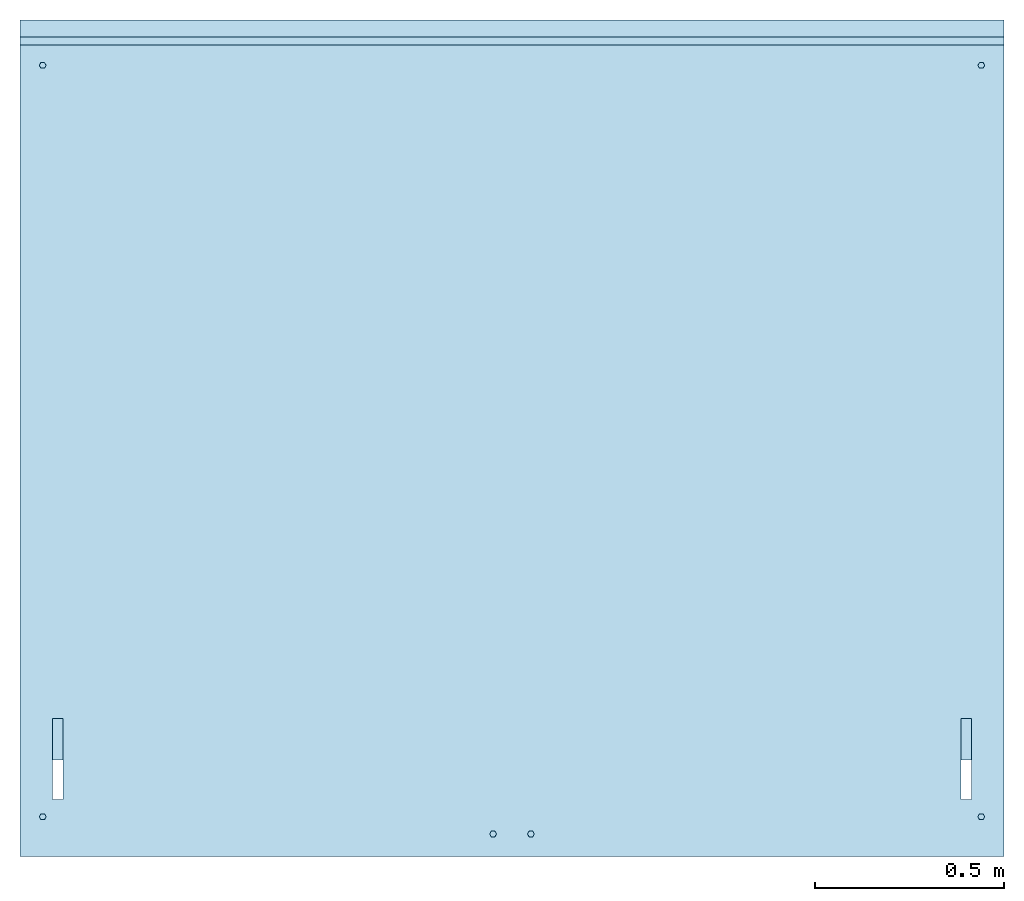
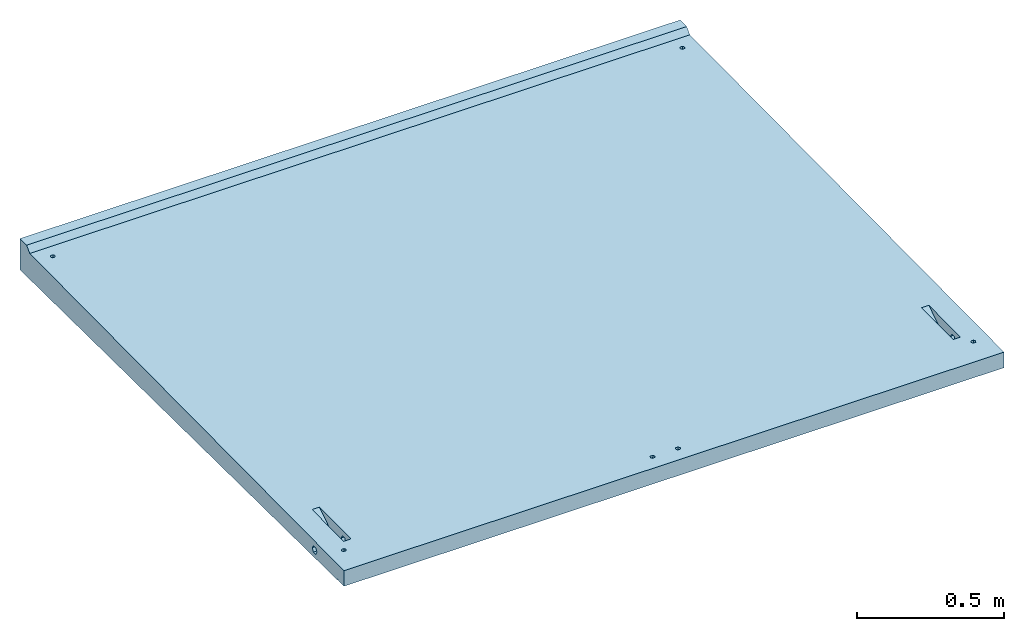
# One storey: 1 slab.
"""IFC2X3 building model written with IfcOpenShell, lengths in millimetres."""

from ifc_helpers import new_model, entity, si_unit, converted_unit, derived_unit, direction, frame, origin, place, context, subcontext, project, spatial, faceted_brep, material, type_object, element, save


model = new_model("IFC2X3")

# Units and contexts
model_context = context("Model", 3, precision=0.01, world=origin(), true_north=direction((6.12303176911189e-17, 1.0)))
body_context = subcontext(model_context, "Body", "Model", "MODEL_VIEW")
ifc_project = project(units=[si_unit("LENGTHUNIT", "METRE", prefix="MILLI"), si_unit("AREAUNIT", "SQUARE_METRE"), si_unit("VOLUMEUNIT", "CUBIC_METRE"), converted_unit("PLANEANGLEUNIT", "DEGREE", entity("IfcRatioMeasure", 0.0174532925199433), si_unit("PLANEANGLEUNIT", "RADIAN"), dimensions=[0, 0, 0, 0, 0, 0, 0]), si_unit("MASSUNIT", "GRAM", prefix="KILO"), derived_unit("MASSDENSITYUNIT", [(si_unit("MASSUNIT", "GRAM", prefix="KILO"), 1), (si_unit("LENGTHUNIT", "METRE"), -3)]), derived_unit("MOMENTOFINERTIAUNIT", [(si_unit("LENGTHUNIT", "METRE"), 4)]), si_unit("TIMEUNIT", "SECOND"), si_unit("FREQUENCYUNIT", "HERTZ"), si_unit("THERMODYNAMICTEMPERATUREUNIT", "DEGREE_CELSIUS"), derived_unit("THERMALTRANSMITTANCEUNIT", [(si_unit("MASSUNIT", "GRAM", prefix="KILO"), 1), (si_unit("THERMODYNAMICTEMPERATUREUNIT", "KELVIN"), -1), (si_unit("TIMEUNIT", "SECOND"), -3)]), derived_unit("VOLUMETRICFLOWRATEUNIT", [(si_unit("LENGTHUNIT", "METRE"), 3), (si_unit("TIMEUNIT", "SECOND"), -1)]), si_unit("ELECTRICCURRENTUNIT", "AMPERE"), si_unit("ELECTRICVOLTAGEUNIT", "VOLT"), si_unit("POWERUNIT", "WATT"), si_unit("FORCEUNIT", "NEWTON", prefix="KILO"), si_unit("ILLUMINANCEUNIT", "LUX"), si_unit("LUMINOUSFLUXUNIT", "LUMEN"), si_unit("LUMINOUSINTENSITYUNIT", "CANDELA"), derived_unit("USERDEFINED", [(si_unit("MASSUNIT", "GRAM", prefix="KILO"), -1), (si_unit("LENGTHUNIT", "METRE"), -2), (si_unit("TIMEUNIT", "SECOND"), 3), (si_unit("LUMINOUSFLUXUNIT", "LUMEN"), 1)]), derived_unit("LINEARVELOCITYUNIT", [(si_unit("LENGTHUNIT", "METRE"), 1), (si_unit("TIMEUNIT", "SECOND"), -1)]), si_unit("PRESSUREUNIT", "PASCAL"), derived_unit("USERDEFINED", [(si_unit("LENGTHUNIT", "METRE"), -2), (si_unit("MASSUNIT", "GRAM", prefix="KILO"), 1), (si_unit("TIMEUNIT", "SECOND"), -2)]), derived_unit("LINEARFORCEUNIT", [(si_unit("MASSUNIT", "GRAM", prefix="KILO"), 1), (si_unit("LENGTHUNIT", "METRE"), 1), (si_unit("TIMEUNIT", "SECOND"), -2), (si_unit("LENGTHUNIT", "METRE"), -1)]), derived_unit("PLANARFORCEUNIT", [(si_unit("MASSUNIT", "GRAM", prefix="KILO"), 1), (si_unit("LENGTHUNIT", "METRE"), 1), (si_unit("TIMEUNIT", "SECOND"), -2), (si_unit("LENGTHUNIT", "METRE"), -2)])], contexts=[model_context])

# Site, building, storey
site_placement = place(None, origin())
site = spatial("IfcSite", under=ifc_project, at=site_placement, CompositionType="ELEMENT")
building_placement = place(site_placement, origin())
building = spatial("IfcBuilding", under=site, at=building_placement, CompositionType="ELEMENT")
storey_placement = place(building_placement, origin())
storey = spatial("IfcBuildingStorey", under=building, at=storey_placement, Name="Begane Grond", CompositionType="ELEMENT", Elevation=0.0)

# Slab
ifc_material = material(Name="beton_prefab-element")
slab_type = type_object("IfcSlabType", PredefinedType="FLOOR", material=ifc_material)
slab_placement = place(storey_placement, frame((-4979.78640975478, -21298.0180129676, -54.5999999999827)))
element("IfcSlab", 1, at=slab_placement, inside=storey, type_object=slab_type, Name="23_GM_Standaard con R21:con, 2000x2600x65/115", PredefinedType="FLOOR", context=body_context, shape_type="Brep", body=[
    faceted_brep([(64.4999999999962, 97.2057713659394, 48.0600005145843), (69.0, 105.0, 48.0600005145843), (64.4999999999962, 112.794228634056, 48.0600005145843), (55.499999999996, 112.794228634056, 48.0600005145843), (51.0, 105.0, 48.0600005145843), (55.499999999996, 97.2057713659394, 48.0600005145843), (1245.5, 67.0942286340536, 48.0600005145843), (1241.0, 59.2999999999952, 48.0600005145843), (1245.5, 51.5057713659368, 48.0600005145843), (1254.5, 51.5057713659368, 48.0600005145843), (1259.0, 59.2999999999952, 48.0600005145843), (1254.5, 67.0942286340536, 48.0600005145843), (2544.5, 97.2057713659307, 48.0600005145843), (2549.0, 105.0, 48.0600005145843), (2544.5, 112.794228634048, 48.0600005145843), (2535.5, 112.794228634048, 48.0600005145843), (2531.0, 105.0, 48.0600005145843), (2535.5, 97.2057713659307, 48.0600005145843), (1345.5, 67.0942286340536, 48.0600005145843), (1341.0, 59.2999999999952, 48.0600005145843), (1345.5, 51.5057713659324, 48.0600005145843), (1354.5, 51.5057713659324, 48.0600005145843), (1359.0, 59.2999999999952, 48.0600005145843), (1354.5, 67.0942286340536, 48.0600005145843), (55.4999999999993, 2082.20577136594, 67.9100005145707), (64.4999999999994, 2082.20577136594, 67.9100005145707), (69.0, 2090.0, 67.9100005145707), (64.4999999999994, 2097.79422863406, 67.9100005145707), (55.4999999999993, 2097.79422863406, 67.9100005145707), (51.0, 2090.0, 67.9100005145707), (2535.5, 2082.20577136594, 67.9100005145707), (2544.5, 2082.20577136594, 67.9100005145707), (2549.0, 2090.0, 67.9100005145707), (2544.5, 2097.79422863406, 67.9100005145707), (2535.5, 2097.79422863406, 67.9100005145707), (2531.0, 2090.0, 67.9100005145707), (2514.67446595528, 192.0, 38.2435935394484), (2514.67446595528, 190.182514765439, 41.3915703077247), (2514.67446595528, 188.36502953087, 44.539547076001), (2514.67446595528, 186.182514765436, 48.3197735380003), (2514.67446595528, 184.0, 52.0999999999995), (2600.0, 184.0, 52.0999999999995), (2600.0, 186.182514767506, 48.3197735344125), (2600.0, 188.0, 45.171796769724), (2600.0, 190.0, 41.7076951545862), (2600.0, 192.0, 38.2435935394484), (114.075534044746, 192.0, 38.2435935394484), (114.075534044746, 190.605222844014, 40.6594184388577), (114.075534044746, 189.210445688023, 43.075243338267), (114.075534044745, 186.60522284401, 47.5876216691333), (114.075534044746, 184.0, 52.0999999999995), (400.0, 184.0, 52.0999999999995), (400.0, 186.605222844123, 47.5876216689416), (400.0, 188.0, 45.171796769724), (400.0, 190.0, 41.7076951545862), (400.0, 192.0, 38.2435935394484), (2200.0, 192.0, 38.2435935394484), (2200.0, 190.605222844014, 40.6594184388616), (2200.0, 189.210445688023, 43.0752433382748), (2200.0, 186.60522284401, 47.5876216691372), (2200.0, 184.0, 52.0999999999995), (2485.92446595528, 184.0, 52.0999999999994), (2485.92446595528, 186.605222844075, 47.5876216690292), (2485.92446595528, 188.0, 45.171796769724), (2485.92446595528, 190.0, 41.7076951545862), (2485.92446595528, 192.0, 38.2435935394484), (0.0, 192.0, 38.2435935394484), (0.0, 190.182514761589, 41.3915703143931), (0.0, 188.365029523169, 44.5395470893379), (0.0, 186.182514761585, 48.3197735446687), (0.0, 184.0, 52.0999999999995), (85.3255340447465, 184.0, 52.0999999999994), (85.3255340447465, 186.182514762092, 48.3197735437932), (85.3255340447465, 188.0, 45.171796769724), (85.3255340447465, 190.0, 41.7076951545862), (85.3255340447465, 192.0, 38.2435935394484), (2600.0, 200.0, 38.2435935394484), (2600.0, 204.0, 38.2435935394484), (2600.0, 208.0, 38.2435935394483), (2514.67446595528, 208.0, 38.2435935394483), (2514.67446595528, 204.0, 38.2435935394484), (2514.67446595528, 200.0, 38.2435935394484), (2514.67446595528, 196.0, 38.2435935394484), (2600.0, 196.0, 38.2435935394484), (400.0, 200.0, 38.2435935394484), (400.0, 204.0, 38.2435935394484), (400.0, 208.0, 38.2435935394483), (114.075534044746, 208.0, 38.2435935394483), (114.075534044746, 204.0, 38.2435935394484), (114.075534044746, 200.0, 38.2435935394484), (114.075534044746, 196.0, 38.2435935394484), (400.0, 196.0, 38.2435935394484), (2485.92446595528, 208.0, 38.2435935394483), (2200.0, 208.0, 38.2435935394483), (2200.0, 204.0, 38.2435935394484), (2200.0, 200.0, 38.2435935394484), (2200.0, 196.0, 38.2435935394484), (2485.92446595528, 196.0, 38.2435935394484), (2485.92446595528, 200.0, 38.2435935394484), (2485.92446595528, 204.0, 38.2435935394484), (85.3255340447465, 208.0, 38.2435935394483), (0.0, 208.0, 38.2435935394483), (0.0, 204.0, 38.2435935394484), (0.0, 200.0, 38.2435935394484), (0.0, 196.0, 38.2435935394484), (85.3255340447465, 196.0, 38.2435935394484), (85.3255340447465, 200.0, 38.2435935394484), (85.3255340447465, 204.0, 38.2435935394484), (2600.0, 210.0, 41.7076951545861), (2600.0, 212.0, 45.1717967697239), (2600.0, 213.817485237319, 48.3197735427603), (2600.0, 216.0, 52.0999999999994), (2514.67446595528, 216.0, 52.0999999999993), (2514.67446595528, 214.0, 48.6358983848615), (2514.67446595528, 212.0, 45.1717967697238), (2514.67446595528, 210.0, 41.7076951545861), (400.0, 210.0, 41.7076951545861), (400.0, 212.0, 45.1717967697238), (400.0, 213.394777155968, 47.5876216690946), (400.0, 216.0, 52.0999999999995), (114.075534044746, 216.0, 52.0999999999995), (114.075534044745, 214.0, 48.6358983848615), (114.075534044746, 212.0, 45.1717967697238), (114.075534044746, 210.0, 41.7076951545861), (2200.0, 214.0, 48.6358983848615), (2200.0, 212.0, 45.1717967697238), (2200.0, 210.0, 41.7076951545861), (2485.92446595528, 210.0, 41.7076951545861), (2485.92446595528, 212.0, 45.1717967697239), (2485.92446595528, 213.394777155981, 47.5876216691147), (2485.92446595528, 216.0, 52.0999999999994), (2200.0, 216.0, 52.0999999999995), (0.0, 214.0, 48.6358983848615), (0.0, 212.0, 45.1717967697238), (0.0, 210.0, 41.7076951545861), (85.3255340447465, 210.0, 41.7076951545861), (85.3255340447465, 212.0, 45.1717967697238), (85.3255340447465, 213.817485238358, 48.3197735445614), (85.3255340447465, 216.0, 52.0999999999994), (0.0, 216.0, 52.0999999999996), (2600.0, 212.0, 59.0282032302751), (2600.0, 210.0, 62.4923048454128), (2600.0, 208.0, 65.9564064605506), (2514.67446595528, 208.0, 65.9564064605506), (2514.67446595528, 210.0, 62.4923048454128), (2514.67446595528, 212.0, 59.028203230275), (2514.67446595528, 214.0, 55.5641016151372), (2600.0, 213.817485194143, 55.8802265320185), (400.0, 210.0, 62.4923048454128), (400.0, 208.0, 65.9564064605506), (114.075534044746, 208.0, 65.9564064605506), (114.075534044745, 210.0, 62.4923048454128), (114.075534044746, 212.0, 59.028203230275), (114.075534044746, 214.0, 55.5641016151372), (400.0, 213.394777130205, 56.6123783755319), (400.0, 212.0, 59.028203230275), (2200.0, 210.0, 62.4923048454128), (2200.0, 212.0, 59.028203230275), (2200.0, 214.0, 55.5641016151372), (2485.92446595528, 213.394777127472, 56.6123783802622), (2485.92446595528, 212.0, 59.0282032302751), (2485.92446595528, 210.0, 62.4923048454128), (2485.92446595528, 208.0, 65.9564064605506), (2200.0, 208.0, 65.9564064605506), (85.3255340447465, 210.0, 62.4923048454128), (85.3255340447465, 208.0, 65.9564064605506), (0.0, 208.0, 65.9564064605506), (0.0, 210.0, 62.4923048454128), (0.0, 212.0, 59.028203230275), (0.0, 214.0, 55.5641016151372), (85.3255340447465, 213.817485136487, 55.880226631878), (85.3255340447465, 212.0, 59.0282032302751), (2514.67446595528, 200.0, 65.9564064605506), (2514.67446595528, 204.0, 65.9564064605506), (2600.0, 204.0, 65.9564064605506), (2600.0, 200.0, 65.9564064605506), (2600.0, 196.0, 65.9564064605506), (2600.0, 192.0, 65.9564064605506), (2514.67446595528, 192.0, 65.9564064605506), (2514.67446595528, 196.0, 65.9564064605506), (114.075534044746, 200.0, 65.9564064605506), (114.075534044746, 204.0, 65.9564064605506), (400.0, 204.0, 65.9564064605506), (400.0, 200.0, 65.9564064605506), (400.0, 196.0, 65.9564064605506), (400.0, 192.0, 65.9564064605506), (114.075534044746, 192.0, 65.9564064605506), (114.075534044745, 196.0, 65.9564064605506), (2485.92446595528, 192.0, 65.9564064605505), (2200.0, 192.0, 65.9564064605506), (2200.0, 196.0, 65.9564064605506), (2200.0, 200.0, 65.9564064605506), (2200.0, 204.0, 65.9564064605506), (2485.92446595528, 204.0, 65.9564064605506), (2485.92446595528, 200.0, 65.9564064605506), (2485.92446595528, 196.0, 65.9564064605506), (85.3255340447465, 192.0, 65.9564064605505), (0.0, 192.0, 65.9564064605505), (0.0, 196.0, 65.9564064605506), (0.0, 200.0, 65.9564064605506), (0.0, 204.0, 65.9564064605506), (85.3255340447465, 204.0, 65.9564064605506), (85.3255340447465, 200.0, 65.9564064605506), (85.3255340447465, 196.0, 65.9564064605506), (2514.67446595528, 188.0, 59.028203230275), (2514.67446595528, 190.0, 62.4923048454128), (2600.0, 190.0, 62.4923048454128), (2600.0, 188.0, 59.028203230275), (2600.0, 186.182514768485, 55.8802264672793), (2514.67446595528, 186.0, 55.5641016151373), (114.075534044746, 190.0, 62.4923048454128), (400.0, 190.605222844273, 63.5405815615906), (400.0, 189.210445688543, 61.1247566626306), (400.0, 186.605222844274, 56.6123783313151), (114.075534044745, 186.605222844014, 56.6123783308729), (114.075534044745, 188.0, 59.028203230275), (2200.0, 188.0, 59.028203230275), (2200.0, 190.0, 62.4923048454128), (2485.92446595528, 190.0, 62.4923048454128), (2485.92446595528, 188.0, 59.028203230275), (2485.92446595528, 186.605222844157, 56.6123783311158), (2200.0, 186.0, 55.5641016151373), (85.3255340447465, 190.0, 62.4923048454128), (85.3255340447465, 188.0, 59.028203230275), (85.3255340447465, 186.182514762209, 55.8802264564145), (0.0, 186.0, 55.5641016151373), (0.0, 188.0, 59.028203230275), (0.0, 190.0, 62.4923048454128), (0.0, 2210.0, 0.0), (0.0, 44.9997500187486, 21.6500024998128), (0.0, 2143.53535353534, 108.535353535339), (0.0, 0.0, 87.1000000000002), (0.0, 42.5431741146631, 26.0049117787142), (0.0, 37.5434240959141, 26.0549092789018), (0.0, 0.0, 22.1000000000001), (0.0, 35.0002499812506, 21.7499975001876), (0.0, 2210.0, 130.0), (0.0, 2165.0, 130.0), (2600.0, 44.9997500187486, 21.6500024998126), (2600.0, 2210.0, 0.0), (2600.0, 42.5431741146631, 26.0049117787142), (2600.0, 2143.53535353534, 108.535353535339), (2600.0, 2210.0, 130.0), (2600.0, 2165.0, 130.0), (2600.0, 0.0, 87.1000000000002), (2600.0, 37.5434240959141, 26.0549092789018), (2600.0, 0.0, 22.1000000000001), (2600.0, 35.0002499812506, 21.7499975001877), (65.1125827205766, 97.5931452069538, 88.0759314520691), (54.8874172794156, 97.5931452069538, 88.0759314520691), (114.075534044746, 150.0, 88.5999999999992), (51.0, 105.0, 88.1499999999995), (85.3255340447465, 365.0, 90.7499999999978), (1244.88741727942, 51.8931452069512, 87.6189314520694), (1255.11258272058, 51.8931452069512, 87.6189314520694), (1344.88741727942, 51.8931452069512, 87.6189314520694), (1355.11258272058, 51.8931452069512, 87.6189314520694), (2485.92446595528, 150.0, 88.5999999999992), (2534.88741727941, 97.5931452069451, 88.075931452069), (2545.11258272058, 97.5931452069451, 88.075931452069), (2549.0, 105.0, 88.1499999999994), (2514.67446595528, 365.0, 90.7499999999978), (2534.88741727942, 2097.40685479304, 108.074068547917), (2545.11258272058, 2097.40685479304, 108.074068547917), (2549.0, 2090.0, 108.0), (2545.11258272058, 2082.59314520695, 107.925931452056), (2545.11258272058, 112.406854793033, 88.2240685479298), (2514.67446595528, 150.0, 88.5999999999992), (2534.88741727942, 2082.59314520695, 107.925931452056), (2485.92446595528, 365.0, 90.7499999999978), (2531.0, 105.0, 88.1499999999994), (2534.88741727941, 112.406854793033, 88.2240685479298), (1359.0, 59.2999999999909, 87.6929999999998), (1355.11258272058, 66.7068547930349, 87.7670685479301), (1341.0, 59.2999999999909, 87.6929999999998), (1259.0, 59.2999999999952, 87.6929999999998), (1344.88741727942, 66.7068547930349, 87.7670685479301), (1255.11258272058, 66.7068547930349, 87.7670685479302), (2531.0, 2090.0, 108.0), (69.0, 2090.0, 108.0), (65.1125827205788, 2082.59314520695, 107.925931452056), (1244.88741727942, 66.7068547930349, 87.7670685479302), (1241.0, 59.2999999999952, 87.6929999999998), (114.075534044746, 365.0, 90.7499999999978), (69.0, 105.0, 88.1499999999995), (85.3255340447465, 150.0, 88.5999999999992), (65.1125827205766, 112.406854793042, 88.2240685479299), (54.8874172794156, 112.406854793042, 88.2240685479299), (54.8874172794188, 2082.59314520695, 107.925931452056), (51.0, 2090.0, 108.0), (54.8874172794177, 2097.40685479304, 108.074068547917), (65.1125827205788, 2097.40685479304, 108.074068547917), (114.075534044746, 255.0, 19.5500000000001), (85.3255340447465, 255.0, 19.5500000000001), (2485.92446595528, 255.0, 19.5500000000001), (2514.67446595528, 255.0, 19.5500000000001), (2514.67446595528, 150.0, 20.6000000000001), (2485.92446595528, 150.0, 20.6000000000001), (85.3255340447465, 150.0, 20.6000000000001), (114.075534044746, 150.0, 20.6000000000001)], [[[0, 1, 2, 3, 4, 5]], [[6, 7, 8, 9, 10, 11]], [[12, 13, 14, 15, 16, 17]], [[18, 19, 20, 21, 22, 23]], [[24, 25, 26, 27, 28, 29]], [[30, 31, 32, 33, 34, 35]], [[36, 37, 38, 39, 40, 41, 42, 43, 44, 45]], [[46, 47, 48, 49, 50, 51, 52, 53, 54, 55]], [[56, 57, 58, 59, 60, 61, 62, 63, 64, 65]], [[66, 67, 68, 69, 70, 71, 72, 73, 74, 75]], [[76, 77, 78, 79, 80, 81, 82, 36, 45, 83]], [[84, 85, 86, 87, 88, 89, 90, 46, 55, 91]], [[92, 93, 94, 95, 96, 56, 65, 97, 98, 99]], [[100, 101, 102, 103, 104, 66, 75, 105, 106, 107]], [[79, 78, 108, 109, 110, 111, 112, 113, 114, 115]], [[87, 86, 116, 117, 118, 119, 120, 121, 122, 123]], [[124, 125, 126, 93, 92, 127, 128, 129, 130, 131]], [[132, 133, 134, 101, 100, 135, 136, 137, 138, 139]], [[140, 141, 142, 143, 144, 145, 146, 112, 111, 147]], [[148, 149, 150, 151, 152, 153, 120, 119, 154, 155]], [[156, 157, 158, 131, 130, 159, 160, 161, 162, 163]], [[164, 165, 166, 167, 168, 169, 139, 138, 170, 171]], [[172, 173, 143, 142, 174, 175, 176, 177, 178, 179]], [[180, 181, 150, 149, 182, 183, 184, 185, 186, 187]], [[188, 189, 190, 191, 192, 163, 162, 193, 194, 195]], [[196, 197, 198, 199, 200, 166, 165, 201, 202, 203]], [[204, 205, 178, 177, 206, 207, 208, 41, 40, 209]], [[210, 186, 185, 211, 212, 213, 51, 50, 214, 215]], [[216, 217, 189, 188, 218, 219, 220, 61, 60, 221]], [[197, 196, 222, 223, 224, 71, 70, 225, 226, 227]], [[101, 228, 229]], [[101, 230, 228]], [[230, 101, 134]], [[229, 102, 101]], [[230, 134, 133]], [[230, 133, 132]], [[230, 132, 139]], [[230, 139, 169]], [[230, 169, 168]], [[230, 168, 167]], [[230, 167, 166]], [[166, 231, 230]], [[231, 166, 200]], [[231, 200, 199]], [[231, 199, 198]], [[231, 198, 197]], [[197, 232, 231]], [[232, 197, 227]], [[232, 227, 226]], [[232, 226, 225]], [[232, 225, 70]], [[70, 229, 232]], [[229, 70, 69]], [[229, 69, 68]], [[229, 68, 67]], [[229, 67, 66]], [[229, 66, 104]], [[229, 104, 103]], [[229, 103, 102]], [[232, 233, 231]], [[231, 233, 234]], [[233, 235, 234]], [[236, 228, 230]], [[230, 237, 236]], [[238, 239, 78]], [[238, 78, 77]], [[238, 77, 76]], [[238, 76, 83]], [[238, 83, 45]], [[238, 45, 44]], [[238, 44, 43]], [[238, 43, 42]], [[238, 42, 41]], [[240, 238, 41]], [[239, 241, 78]], [[241, 239, 242]], [[242, 243, 241]], [[241, 108, 78]], [[241, 109, 108]], [[241, 110, 109]], [[241, 111, 110]], [[241, 147, 111]], [[241, 140, 147]], [[241, 141, 140]], [[241, 142, 141]], [[241, 244, 142]], [[244, 245, 240]], [[246, 245, 244]], [[244, 240, 177]], [[244, 177, 176]], [[244, 176, 175]], [[244, 175, 174]], [[244, 174, 142]], [[246, 247, 245]], [[240, 41, 208]], [[240, 208, 207]], [[240, 207, 206]], [[240, 206, 177]], [[231, 234, 246, 244]], [[231, 248, 249]], [[250, 248, 231]], [[231, 249, 251]], [[231, 251, 252]], [[250, 231, 253]], [[254, 253, 231]], [[231, 255, 254]], [[230, 231, 252]], [[255, 231, 244]], [[256, 255, 244]], [[256, 244, 257]], [[258, 257, 244]], [[258, 244, 259]], [[259, 244, 260]], [[244, 261, 260]], [[244, 241, 261]], [[262, 241, 230]], [[262, 263, 241]], [[241, 263, 264]], [[264, 265, 241]], [[265, 261, 241]], [[266, 260, 261]], [[266, 261, 267]], [[265, 268, 261]], [[261, 268, 269]], [[270, 267, 257]], [[267, 270, 271]], [[271, 266, 267]], [[270, 257, 258]], [[257, 272, 256]], [[257, 269, 272]], [[273, 272, 269]], [[255, 274, 254]], [[254, 274, 275]], [[274, 276, 275]], [[277, 275, 276]], [[268, 276, 273]], [[276, 268, 278]], [[278, 277, 276]], [[268, 273, 269]], [[279, 277, 278]], [[280, 277, 279]], [[280, 281, 277]], [[282, 250, 253]], [[281, 283, 282]], [[250, 282, 283]], [[283, 281, 280]], [[280, 252, 283]], [[284, 248, 250]], [[285, 284, 250]], [[284, 285, 286]], [[285, 252, 287]], [[286, 285, 287]], [[251, 287, 252]], [[280, 288, 252]], [[288, 230, 252]], [[288, 289, 230]], [[290, 230, 289]], [[230, 290, 291]], [[230, 291, 262]], [[262, 291, 278]], [[278, 291, 279]], [[228, 236, 242, 239]], [[228, 292, 293]], [[292, 228, 239]], [[228, 293, 229]], [[239, 294, 292]], [[294, 239, 295]], [[295, 239, 238]], [[238, 296, 295]], [[297, 296, 238]], [[297, 238, 229]], [[298, 229, 293]], [[229, 298, 299]], [[229, 299, 297]], [[294, 297, 299]], [[292, 294, 299]], [[234, 235, 247, 246]], [[238, 240, 232, 229]], [[240, 245, 233, 232]], [[245, 247, 235, 233]], [[237, 230, 241, 243]], [[236, 237, 243, 242]], [[250, 150, 181]], [[250, 283, 150]], [[250, 181, 180]], [[250, 180, 187]], [[250, 187, 186]], [[250, 186, 210]], [[250, 210, 215]], [[250, 215, 214]], [[250, 214, 50]], [[250, 50, 299]], [[283, 151, 150]], [[283, 152, 151]], [[283, 153, 152]], [[283, 120, 153]], [[292, 120, 283]], [[292, 299, 87]], [[292, 87, 123]], [[292, 123, 122]], [[292, 122, 121]], [[292, 121, 120]], [[299, 50, 49]], [[299, 49, 48]], [[299, 48, 47]], [[299, 47, 46]], [[299, 46, 90]], [[299, 90, 89]], [[299, 89, 88]], [[299, 88, 87]], [[298, 75, 74]], [[298, 74, 73]], [[298, 73, 72]], [[298, 72, 71]], [[285, 298, 71]], [[298, 105, 75]], [[298, 106, 105]], [[298, 107, 106]], [[298, 100, 107]], [[293, 100, 298]], [[293, 135, 100]], [[293, 136, 135]], [[293, 137, 136]], [[293, 138, 137]], [[293, 252, 138]], [[285, 165, 252]], [[252, 165, 164]], [[252, 164, 171]], [[252, 171, 170]], [[252, 170, 138]], [[285, 71, 224]], [[285, 224, 223]], [[285, 223, 222]], [[285, 222, 196]], [[285, 196, 203]], [[285, 203, 202]], [[285, 202, 201]], [[285, 201, 165]], [[285, 250, 299, 298]], [[257, 267, 296, 297]], [[293, 292, 283, 252]], [[294, 295, 261, 269]], [[267, 143, 173]], [[267, 261, 143]], [[267, 173, 172]], [[267, 172, 179]], [[267, 179, 178]], [[267, 178, 205]], [[267, 205, 204]], [[267, 204, 209]], [[267, 209, 40]], [[267, 40, 296]], [[261, 144, 143]], [[261, 145, 144]], [[261, 146, 145]], [[261, 112, 146]], [[295, 112, 261]], [[295, 296, 79]], [[295, 79, 115]], [[295, 115, 114]], [[295, 114, 113]], [[295, 113, 112]], [[296, 40, 39]], [[296, 39, 38]], [[296, 38, 37]], [[296, 37, 36]], [[296, 36, 82]], [[296, 82, 81]], [[296, 81, 80]], [[296, 80, 79]], [[297, 65, 64]], [[297, 64, 63]], [[297, 63, 62]], [[297, 62, 61]], [[257, 297, 61]], [[297, 97, 65]], [[297, 98, 97]], [[297, 99, 98]], [[297, 92, 99]], [[294, 92, 297]], [[294, 127, 92]], [[294, 128, 127]], [[294, 129, 128]], [[294, 130, 129]], [[294, 269, 130]], [[257, 162, 269]], [[269, 162, 161]], [[269, 161, 160]], [[269, 160, 159]], [[269, 159, 130]], [[257, 61, 220]], [[257, 220, 219]], [[257, 219, 218]], [[257, 218, 188]], [[257, 188, 195]], [[257, 195, 194]], [[257, 194, 193]], [[257, 193, 162]], [[59, 58, 57, 56, 96, 95, 94, 93, 126, 125, 124, 131, 158, 157, 156, 163, 192, 191, 190, 189, 217, 216, 221, 60]], [[85, 84, 91, 55, 54, 53, 52, 51, 213, 212, 211, 185, 184, 183, 182, 149, 148, 155, 154, 119, 118, 117, 116, 86]], [[249, 5, 4]], [[4, 251, 249]], [[249, 248, 0, 5]], [[258, 259, 12, 17]], [[248, 1, 0]], [[1, 248, 284]], [[286, 2, 1]], [[1, 284, 286]], [[286, 287, 3, 2]], [[266, 271, 15, 14]], [[287, 4, 3]], [[4, 287, 251]], [[258, 17, 16]], [[16, 270, 258]], [[259, 13, 12]], [[13, 259, 260]], [[266, 14, 13]], [[13, 260, 266]], [[271, 16, 15]], [[16, 271, 270]], [[288, 24, 29]], [[29, 289, 288]], [[288, 280, 25, 24]], [[268, 265, 31, 30]], [[280, 26, 25]], [[26, 280, 279]], [[291, 27, 26]], [[26, 279, 291]], [[291, 290, 28, 27]], [[263, 262, 34, 33]], [[290, 29, 28]], [[29, 290, 289]], [[268, 30, 35]], [[35, 278, 268]], [[265, 32, 31]], [[32, 265, 264]], [[263, 33, 32]], [[32, 264, 263]], [[262, 35, 34]], [[35, 262, 278]], [[253, 8, 7]], [[7, 282, 253]], [[253, 254, 9, 8]], [[255, 256, 21, 20]], [[254, 10, 9]], [[10, 254, 275]], [[277, 11, 10]], [[10, 275, 277]], [[277, 281, 6, 11]], [[273, 276, 18, 23]], [[281, 7, 6]], [[7, 281, 282]], [[255, 20, 19]], [[19, 274, 255]], [[256, 22, 21]], [[22, 256, 272]], [[273, 23, 22]], [[22, 272, 273]], [[276, 19, 18]], [[19, 276, 274]]]),
])

save(model, "model.ifc")
